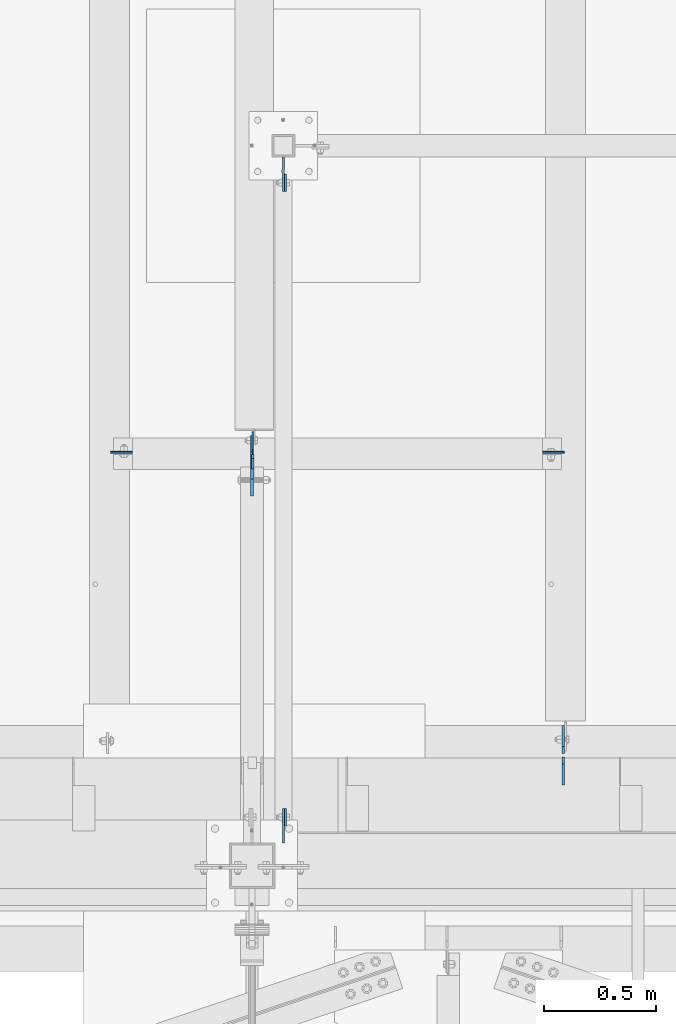
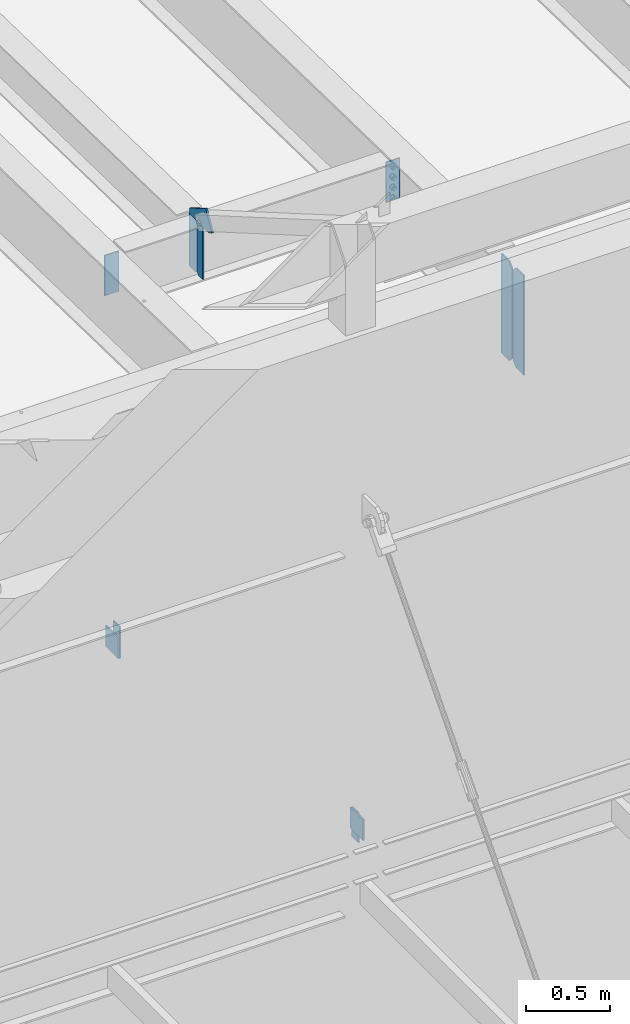
# One storey, part 1458 of 1763: 11 plates, 7 elements without a shape of their own.
"""IFC2X3 building model written with IfcOpenShell, lengths in millimetres."""

import ifcopenshell
import ifcopenshell.guid

model = None  # the IFC model being written
_history = None  # IfcOwnerHistory: only IFC2X3 demands one
_inside = {}  # id of a spatial element -> (the spatial element, [elements in it])
_under = {}  # id of a project, library or spatial element -> (it, [spatial elements below it])
_declared = {}  # id of a project -> (the project, [libraries it declares])
_typed = {}  # id of a type object -> (the type object, [elements of that type])
_made_of = {}  # id of a material, layer set ... -> (it, [elements and type objects made of it])


def new_model(schema):
    """Start an empty IFC model of exactly this schema.

    Asked for "IFC4X3", IfcOpenShell would pick the latest addendum, in which some entities
    have other attributes; the version numbers below select the first issue.
    IFC2X3 requires an IfcOwnerHistory on every rooted entity: one is made here for all.
    """
    global model, _history
    if schema == "IFC4X3":
        model = ifcopenshell.file(schema_version=(4, 3, 0, 0))
    else:
        model = ifcopenshell.file(schema=schema)
    _inside.clear()
    _under.clear()
    _declared.clear()
    _typed.clear()
    _made_of.clear()
    _history = None
    if model.schema == "IFC2X3":
        org = make("IfcOrganization", Name="unknown")
        user = make(
            "IfcPersonAndOrganization",
            ThePerson=make("IfcPerson", FamilyName="unknown"),
            TheOrganization=org,
        )
        app = make(
            "IfcApplication",
            ApplicationDeveloper=org,
            Version="unknown",
            ApplicationFullName="unknown",
            ApplicationIdentifier="unknown",
        )
        _history = make(
            "IfcOwnerHistory",
            OwningUser=user,
            OwningApplication=app,
            ChangeAction="ADDED",
            CreationDate=0,
        )
    return model


def make(cls, **values):
    """One entity of the class cls with the attributes given. An attribute that is None is left unset."""
    return model.create_entity(
        cls, **{name: value for name, value in values.items() if value is not None}
    )


def rooted(cls, **values):
    """An entity with a GlobalId (a new one), such as an element, a storey or a relation."""
    return make(cls, GlobalId=ifcopenshell.guid.new(), OwnerHistory=_history, **values)


def si_unit(unit_type, name, prefix=None):
    """IfcSIUnit, for example si_unit("LENGTHUNIT", "METRE", prefix="MILLI")."""
    return make("IfcSIUnit", UnitType=unit_type, Prefix=prefix, Name=name)


def assignment(units):
    """IfcUnitAssignment: the units of a project."""
    return None if units is None else make("IfcUnitAssignment", Units=units)


def point(xyz):
    """IfcCartesianPoint."""
    return None if xyz is None else make("IfcCartesianPoint", Coordinates=xyz)


def direction(xyz):
    """IfcDirection."""
    return None if xyz is None else make("IfcDirection", DirectionRatios=xyz)


def frame(location, z_axis=None, x_axis=None):
    """IfcAxis2Placement3D, a coordinate frame: its origin and axes. An axis left out is left unset."""
    return make(
        "IfcAxis2Placement3D",
        Location=point(location),
        Axis=direction(z_axis),
        RefDirection=direction(x_axis),
    )


def origin_with_axes():
    """The frame at (0, 0, 0) with the z axis (0, 0, 1) and the x axis (1, 0, 0) written out."""
    return frame((0.0, 0.0, 0.0), z_axis=(0.0, 0.0, 1.0), x_axis=(1.0, 0.0, 0.0))


def place(relative_to, where):
    """IfcLocalPlacement: puts the frame where relative to a parent placement (None: the world)."""
    return make(
        "IfcLocalPlacement", PlacementRelTo=relative_to, RelativePlacement=where
    )


def context(
    kind, dimensions, precision=None, world=None, true_north=None, identifier=None
):
    """IfcGeometricRepresentationContext, for example the 3D "Model" context."""
    return make(
        "IfcGeometricRepresentationContext",
        ContextIdentifier=identifier,
        ContextType=kind,
        CoordinateSpaceDimension=dimensions,
        Precision=precision,
        WorldCoordinateSystem=world,
        TrueNorth=true_north,
    )


def subcontext(parent, identifier, kind, view, scale=None):
    """IfcGeometricRepresentationSubContext, for example "Body" below "Model"."""
    return make(
        "IfcGeometricRepresentationSubContext",
        ContextIdentifier=identifier,
        ContextType=kind,
        ParentContext=parent,
        TargetScale=scale,
        TargetView=view,
    )


def project(units=None, contexts=None):
    """IfcProject with its units and contexts."""
    return rooted(
        "IfcProject",
        Name="project",
        RepresentationContexts=contexts,
        UnitsInContext=assignment(units),
    )


def spatial(cls, under=None, at=None, **own):
    """A site, building, storey or space (cls), placed at a placement, below another one or the project."""
    s = rooted(cls, ObjectPlacement=at, **own)
    if under is not None:
        _under.setdefault(under.id(), (under, []))[1].append(s)
    return s


def faces_of(points, faces, orient=None, outer=None):
    """IfcFace entities. A face is a list of loops; a loop is a list of indices into points, from 0.

    orient and outer hold one flag for each loop. By default every Orientation is true, the
    first loop of a face is its IfcFaceOuterBound and the others are IfcFaceBound.
    """
    made = []
    for i, loops in enumerate(faces):
        bounds = []
        for j, loop in enumerate(loops):
            is_outer = j == 0 if outer is None else outer[i][j]
            bounds.append(
                make(
                    "IfcFaceOuterBound" if is_outer else "IfcFaceBound",
                    Bound=make("IfcPolyLoop", Polygon=[points[k] for k in loop]),
                    Orientation=True if orient is None else orient[i][j],
                )
            )
        made.append(make("IfcFace", Bounds=bounds))
    return made


def faceted_brep(points, faces, orient=None, outer=None, voids=None):
    """IfcFacetedBrep: a solid bounded by flat faces; with voids (closed shells), ...WithVoids."""
    shared = [point(p) for p in points]
    hull = make("IfcClosedShell", CfsFaces=faces_of(shared, faces, orient, outer))
    if voids is None:
        return make("IfcFacetedBrep", Outer=hull)
    return make(
        "IfcFacetedBrepWithVoids",
        Outer=hull,
        Voids=[
            make(cls, CfsFaces=faces_of(shared, fs, o, b)) for cls, fs, o, b in voids
        ],
    )


def shape(context_of_items, identifier, shape_type, items):
    """IfcShapeRepresentation: the items that make up one representation, for example the "Body"."""
    return make(
        "IfcShapeRepresentation",
        ContextOfItems=context_of_items,
        RepresentationIdentifier=identifier,
        RepresentationType=shape_type,
        Items=items,
    )


def material(Name=None, Category=None):
    """IfcMaterial."""
    return make("IfcMaterial", Name=Name, Category=Category)


def made_of(thing, what):
    """Note that an element or type object is made of a material, layer set ...; save() writes the relation."""
    if what is not None:
        _made_of.setdefault(what.id(), (what, []))[1].append(thing)
    return thing


def type_object(cls, material=None, **own):
    """A type object (cls), such as IfcWallType, which elements share."""
    return made_of(rooted(cls, **own), material)


def element(
    cls,
    number,
    at=None,
    inside=None,
    cuts=None,
    type_object=None,
    material=None,
    context=None,
    identifier="Body",
    shape_type=None,
    held_by="IfcProductDefinitionShape",
    body=None,
    shapes=None,
    **own,
):
    """One element of the class cls, such as IfcWall. Its Tag is "e" and its number.

    at: its placement. inside: the storey or other place that contains it. cuts: it is an
    opening in that element (IfcRelVoidsElement). A single representation is given by context,
    identifier, shape_type and body (its items); several are given by shapes. held_by: the class
    of the entity that holds the representations. save() writes the other relations.
    """
    e = rooted(cls, Tag="e%d" % number, ObjectPlacement=at, **own)
    if body is not None:
        shapes = [shape(context, identifier, shape_type, body)]
    if shapes is not None:
        e.Representation = make(held_by, Representations=shapes)
    if inside is not None:
        _inside.setdefault(inside.id(), (inside, []))[1].append(e)
    if cuts is not None:
        rooted(
            "IfcRelVoidsElement", RelatingBuildingElement=cuts, RelatedOpeningElement=e
        )
    if type_object is not None:
        _typed.setdefault(type_object.id(), (type_object, []))[1].append(e)
    return made_of(e, material)


def aggregate(whole, parts):
    """IfcRelAggregates: a whole, such as a stair, and the parts it consists of."""
    return rooted("IfcRelAggregates", RelatingObject=whole, RelatedObjects=parts)


def save(model, path):
    """Write the relations noted so far, then the file.

    IfcRelAggregates (storeys below a building ...), IfcRelContainedInSpatialStructure (elements
    in a storey), IfcRelDefinesByType, IfcRelAssociatesMaterial and IfcRelDeclares: one each for
    every whole, place, type object, material and project.
    """
    for whole, parts in _under.values():
        aggregate(whole, parts)
    for where, things in _inside.values():
        rooted(
            "IfcRelContainedInSpatialStructure",
            RelatedElements=things,
            RelatingStructure=where,
        )
    for kind, things in _typed.values():
        rooted("IfcRelDefinesByType", RelatedObjects=things, RelatingType=kind)
    for what, things in _made_of.values():
        rooted("IfcRelAssociatesMaterial", RelatedObjects=things, RelatingMaterial=what)
    for by, libraries in _declared.values():
        rooted("IfcRelDeclares", RelatingContext=by, RelatedDefinitions=libraries)
    model.write(path)


model = new_model("IFC2X3")

# Units and contexts
model_context = context("Model", 3, precision=1e-05, world=origin_with_axes())
body_context = subcontext(model_context, "Body", "Model", "MODEL_VIEW")
ifc_project = project(units=[si_unit("LENGTHUNIT", "METRE", prefix="MILLI"), si_unit("AREAUNIT", "SQUARE_METRE"), si_unit("VOLUMEUNIT", "CUBIC_METRE"), si_unit("MASSUNIT", "GRAM", prefix="KILO"), si_unit("TIMEUNIT", "SECOND"), si_unit("PLANEANGLEUNIT", "RADIAN"), si_unit("SOLIDANGLEUNIT", "STERADIAN"), si_unit("THERMODYNAMICTEMPERATUREUNIT", "DEGREE_CELSIUS"), si_unit("LUMINOUSINTENSITYUNIT", "LUMEN")], contexts=[model_context])

# Site, building, storey
site_placement = place(None, origin_with_axes())
site = spatial("IfcSite", under=ifc_project, at=site_placement, CompositionType="ELEMENT")
building_placement = place(site_placement, origin_with_axes())
building = spatial("IfcBuilding", under=site, at=building_placement, Name="Undefined", CompositionType="ELEMENT")
storey_placement = place(building_placement, origin_with_axes())
storey = spatial("IfcBuildingStorey", under=building, at=storey_placement, Name="Undefined", CompositionType="ELEMENT", Elevation=0.0)

# Assembly, plates
assembly_1_placement = place(storey_placement, origin_with_axes())
assembly_1 = element("IfcElementAssembly", 1, at=assembly_1_placement, inside=storey, Name="BEAM", AssemblyPlace="NOTDEFINED", PredefinedType="RIGID_FRAME")
ifc_material = material(Name="STEEL/A36")
plate_type_1 = type_object("IfcPlateType", PredefinedType="NOTDEFINED")
plate_1_placement = place(assembly_1_placement, frame((-58778.1796871736, -14030.3570889892, 8623.30000007624), z_axis=(0.0, 0.0, 1.0), x_axis=(0.0, 1.0, 0.0)))
plate_1 = element("IfcPlate", 2, at=plate_1_placement, type_object=plate_type_1, material=ifc_material, Name="PLATE", context=body_context, shape_type="Brep", body=[
    faceted_brep([(0.0, -4.76249999999982, 0.0), (0.0294800233077694, -4.76250000068103, 215.899993896486), (0.0294800233114074, 4.76249999931315, 215.899993896483), (0.0, 4.76249999999982, 0.0), (76.2294769287091, -4.76250000057917, 215.899993896486), (76.2294769287128, 4.76249999942229, 215.899993896483), (76.1999969482931, -4.76249999991705, 0.0), (76.1999969482931, 4.76250000006257, 1.81898940354586e-12)], [[[0, 1, 2, 3]], [[1, 4, 5, 2]], [[4, 6, 7, 5]], [[6, 0, 3, 7]], [[5, 7, 3, 2]], [[6, 4, 1, 0]]]),
])
plate_2_placement = place(assembly_1_placement, frame((-58778.1796872498, -11125.1679129386, 8470.89999992377), z_axis=(0.0, 0.0, -1.0), x_axis=(0.0, -1.0, 0.0)))
plate_2 = element("IfcPlate", 3, at=plate_2_placement, type_object=plate_type_1, material=ifc_material, Name="PLATE", context=body_context, shape_type="Brep", body=[
    faceted_brep([(0.0, -4.76249999999982, 0.0), (-2.83762346953154e-10, -4.7624999996915, 228.600006103516), (-2.83762346953154e-10, 4.76250000028813, 228.600006103517), (0.0, 4.76249999999982, 0.0), (76.1999969480166, -4.76249999961874, 228.600006103516), (76.1999969480166, 4.76250000036089, 228.600006103517), (76.1999969482931, -4.76249999991705, 0.0), (76.1999969482931, 4.76250000006257, 1.81898940354586e-12)], [[[0, 1, 2, 3]], [[1, 4, 5, 2]], [[4, 6, 7, 5]], [[6, 0, 3, 7]], [[5, 7, 3, 2]], [[6, 4, 1, 0]]]),
])
aggregate(assembly_1, [plate_1, plate_2])

# Assembly, plate
assembly_2_placement = place(storey_placement, origin_with_axes())
assembly_2 = element("IfcElementAssembly", 4, at=assembly_2_placement, inside=storey, Name="BEAM", AssemblyPlace="NOTDEFINED", PredefinedType="RIGID_FRAME")
plate_type_2 = type_object("IfcPlateType", PredefinedType="NOTDEFINED")
plate_3_placement = place(assembly_2_placement, frame((-58787.7046893278, -13954.1276120796, 8839.19999998095), z_axis=(0.0, 0.0, -1.0), x_axis=(0.0, -1.0, 0.0)))
plate_3 = element("IfcPlate", 5, at=plate_3_placement, type_object=plate_type_2, material=ifc_material, Name="PLATE", context=body_context, shape_type="Brep", body=[
    faceted_brep([(0.0, -4.76249999999982, 0.0), (-3.05175672110636e-06, -4.7625000002663, 152.399993896484), (-3.05175490211695e-06, 4.76249999972788, 152.399993896484), (0.0, 4.76249999999982, 0.0), (152.400009155272, -4.76249999975698, 152.399993896484), (152.400009155273, 4.76250000024447, 152.399993896484), (152.400009155272, -4.76249999948777, 5.45696821063757e-12), (152.400009155273, 4.76250000051368, 3.63797880709171e-12)], [[[0, 1, 2, 3]], [[1, 4, 5, 2]], [[4, 6, 7, 5]], [[6, 0, 3, 7]], [[5, 7, 3, 2]], [[6, 4, 1, 0]]]),
])
aggregate(assembly_2, [plate_3])

assembly_3_placement = place(storey_placement, origin_with_axes())
assembly_3 = element("IfcElementAssembly", 6, at=assembly_3_placement, inside=storey, Name="COLUMN", AssemblyPlace="NOTDEFINED", PredefinedType="RIGID_FRAME")
plate_4_placement = place(assembly_3_placement, frame((-58787.7046893277, -11201.3679099249, 8242.29999389649), z_axis=(0.0, 0.0, 1.0), x_axis=(0.0, 1.0, 0.0)))
plate_4 = element("IfcPlate", 7, at=plate_4_placement, type_object=plate_type_2, material=ifc_material, Name="PLATE", context=body_context, shape_type="Brep", body=[
    faceted_brep([(0.0, -4.76249999999982, 0.0), (-3.05175672110636e-06, -4.7625000002663, 152.399993896484), (-3.05175490211695e-06, 4.76249999972788, 152.399993896484), (0.0, 4.76249999999982, 0.0), (152.400009155272, -4.76249999975698, 152.399993896484), (152.400009155273, 4.76250000024447, 152.399993896484), (152.400009155272, -4.76249999948777, 5.45696821063757e-12), (152.400009155273, 4.76250000051368, 3.63797880709171e-12)], [[[0, 1, 2, 3]], [[1, 4, 5, 2]], [[4, 6, 7, 5]], [[6, 0, 3, 7]], [[5, 7, 3, 2]], [[6, 4, 1, 0]]]),
])
aggregate(assembly_3, [plate_4])

# Assembly, plates
assembly_4_placement = place(storey_placement, origin_with_axes())
assembly_4 = element("IfcElementAssembly", 8, at=assembly_4_placement, inside=storey, Name="BEAM", AssemblyPlace="NOTDEFINED", PredefinedType="RIGID_FRAME")
plate_type_3 = type_object("IfcPlateType", PredefinedType="NOTDEFINED")
plate_5_placement = place(assembly_4_placement, frame((-58924.2622752818, -12368.9394876504, 11786.0798333454), z_axis=(0.0, 0.0, 1.0), x_axis=(0.0, 1.0, 0.0)))
plate_5 = element("IfcPlate", 9, at=plate_5_placement, type_object=plate_type_3, material=ifc_material, Name="PLATE", context=body_context, shape_type="Brep", body=[
    faceted_brep([(0.0, -3.17500000000291, 17.4624996185303), (0.0, -3.17500000000291, 363.53750038147), (0.0, 3.17500000000291, 363.53750038147), (0.0, 3.17500000000291, 17.4624996185303), (17.4624996185303, -3.17500000000291, 381.0), (17.4624996185303, 3.17500000000291, 381.0), (95.25, -3.17500000000291, 381.0), (95.25, 3.17500000000291, 381.0), (95.25, -3.17500000000291, 0.0), (95.25, 3.17500000000291, 0.0), (17.4624996185303, -3.17500000000291, 0.0), (17.4624996185303, 3.17500000000291, 0.0)], [[[0, 1, 2, 3]], [[1, 4, 5, 2]], [[4, 6, 7, 5]], [[6, 8, 9, 7]], [[8, 10, 11, 9]], [[10, 0, 3, 11]], [[5, 7, 9, 11, 3, 2]], [[10, 8, 6, 4, 1, 0]]]),
])
plate_type_4 = type_object("IfcPlateType", PredefinedType="NOTDEFINED")
plate_6_placement = place(assembly_4_placement, frame((-58927.4377751502, -12289.5644876527, 12176.6048333467), z_axis=(0.0, -1.0, 0.0), x_axis=(0.0, 0.0, 1.0)))
plate_6 = element("IfcPlate", 10, at=plate_6_placement, type_object=plate_type_4, material=ifc_material, Name="PLATE", context=body_context, shape_type="Brep", body=[
    faceted_brep([(0.0, -6.34999999999491, 1.45519152283669e-11), (0.0, -6.34999999999854, 165.100006103516), (0.0, 6.34999999999854, 165.100006103516), (0.0, 6.34999999999491, -2.91038304567337e-11), (0.0, -6.34999999999854, 234.421340942383), (0.0, 6.34999999999854, 234.421340942383), (20.8898239135742, -6.34999999999854, 270.436950683594), (20.8898239135742, 6.34999999999854, 270.436950683594), (152.717071533203, -6.34999999999854, 193.974349975586), (152.717071533203, 6.34999999999854, 193.974349975586), (40.2078170776367, -6.34999999999854, 0.0), (40.2078170776367, 6.34999999999854, 0.0)], [[[0, 1, 2, 3]], [[1, 4, 5, 2]], [[4, 6, 7, 5]], [[6, 8, 9, 7]], [[8, 10, 11, 9]], [[10, 0, 3, 11]], [[5, 7, 9, 11, 3, 2]], [[10, 8, 6, 4, 1, 0]]]),
])

# Assembly, plate
assembly_5_placement = place(storey_placement, origin_with_axes())
assembly_5 = element("IfcElementAssembly", 11, at=assembly_5_placement, inside=storey, Name="BEAM", AssemblyPlace="NOTDEFINED", PredefinedType="RIGID_FRAME")
plate_type_5 = type_object("IfcPlateType", PredefinedType="NOTDEFINED")
plate_7_placement = place(assembly_5_placement, frame((-57535.1997736983, -12364.9704876481, 12138.5048333448), z_axis=(-1.0, 0.0, 0.0), x_axis=(0.0, 0.0, -1.0)))
plate_7 = element("IfcPlate", 12, at=plate_7_placement, type_object=plate_type_5, material=ifc_material, Name="PLATE", context=body_context, shape_type="Brep", body=[
    faceted_brep([(0.0, -3.96900000000096, 0.0), (0.0, -3.96899999999914, 96.8375015258789), (0.0, 3.96899999999914, 96.8375015258789), (0.0, 3.96900000000096, 0.0), (292.100006103516, -3.96899999999914, 96.8375015258789), (292.100006103516, 3.96899999999914, 96.8375015258789), (292.100006103516, -3.96899999999914, 0.0), (292.100006103516, 3.96899999999914, 0.0)], [[[0, 1, 2, 3]], [[1, 4, 5, 2]], [[4, 6, 7, 5]], [[6, 0, 3, 7]], [[5, 7, 3, 2]], [[6, 4, 1, 0]]]),
])
aggregate(assembly_5, [plate_7])

assembly_6_placement = place(storey_placement, origin_with_axes())
assembly_6 = element("IfcElementAssembly", 13, at=assembly_6_placement, inside=storey, Name="BEAM", AssemblyPlace="NOTDEFINED", PredefinedType="RIGID_FRAME")
plate_8_placement = place(assembly_6_placement, frame((-59557.6747736983, -12364.9704876481, 12138.5048333448), z_axis=(1.0, 0.0, 0.0), x_axis=(0.0, 0.0, -1.0)))
plate_8 = element("IfcPlate", 14, at=plate_8_placement, type_object=plate_type_5, material=ifc_material, Name="PLATE", context=body_context, shape_type="Brep", body=[
    faceted_brep([(0.0, -3.96900000000096, 0.0), (0.0, -3.96899999999914, 96.8375015258789), (0.0, 3.96899999999914, 96.8375015258789), (0.0, 3.96900000000096, 0.0), (292.100006103516, -3.96899999999914, 96.8375015258789), (292.100006103516, 3.96899999999914, 96.8375015258789), (292.100006103516, -3.96899999999914, 0.0), (292.100006103516, 3.96899999999914, 0.0)], [[[0, 1, 2, 3]], [[1, 4, 5, 2]], [[4, 6, 7, 5]], [[6, 0, 3, 7]], [[5, 7, 3, 2]], [[6, 4, 1, 0]]]),
])
aggregate(assembly_6, [plate_8])

# Assembly, plates
assembly_7_placement = place(storey_placement, origin_with_axes())
assembly_7 = element("IfcElementAssembly", 15, at=assembly_7_placement, inside=storey, Name="BEAM", AssemblyPlace="NOTDEFINED", PredefinedType="RIGID_FRAME")
plate_type_6 = type_object("IfcPlateType", PredefinedType="NOTDEFINED")
plate_9_placement = place(assembly_7_placement, frame((-57539.9627736144, -13723.1435686171, 11464.925), z_axis=(0.0, 0.0, 1.0), x_axis=(0.0, -1.0, 0.0)))
plate_9 = element("IfcPlate", 16, at=plate_9_placement, type_object=plate_type_6, material=ifc_material, Name="PLATE", context=body_context, shape_type="Brep", body=[
    faceted_brep([(0.0, -4.76250000000073, 31.75), (0.0, -4.76249999999709, 688.974975585938), (0.0, 4.76249999999709, 688.974975585938), (0.0, 4.76250000000073, 31.75), (31.75, -4.76249999999709, 720.724975585938), (31.75, 4.76249999999709, 720.724975585938), (126.206253051758, -4.76249999999709, 720.724975585938), (126.206253051758, 4.76249999999709, 720.724975585938), (126.206253051758, -4.76249999999709, 0.0), (126.206253051758, 4.76249999999709, 0.0), (31.75, -4.76250000000073, 0.0), (31.75, 4.76250000000073, 0.0)], [[[0, 1, 2, 3]], [[1, 4, 5, 2]], [[4, 6, 7, 5]], [[6, 8, 9, 7]], [[8, 10, 11, 9]], [[10, 0, 3, 11]], [[5, 7, 9, 11, 3, 2]], [[10, 8, 6, 4, 1, 0]]]),
])
plate_type_7 = type_object("IfcPlateType", PredefinedType="NOTDEFINED")
plate_10_placement = place(assembly_7_placement, frame((-57539.9627736144, -13708.8560686171, 11466.5125), z_axis=(0.0, 0.0, 1.0), x_axis=(0.0, 1.0, 0.0)))
plate_10 = element("IfcPlate", 17, at=plate_10_placement, type_object=plate_type_7, material=ifc_material, Name="PLATE", context=body_context, shape_type="Brep", body=[
    faceted_brep([(0.0, -4.76250000000073, 31.75), (0.0, -4.76249999999709, 687.387512207031), (0.0, 4.76249999999709, 687.387512207031), (0.0, 4.76250000000073, 31.75), (31.75, -4.76249999999709, 719.137512207031), (31.75, 4.76249999999709, 719.137512207031), (125.412498474121, -4.76249999999709, 719.137512207031), (125.412498474121, 4.76249999999709, 719.137512207031), (125.412498474121, -4.76249999999709, 0.0), (125.412498474121, 4.76249999999709, 0.0), (31.75, -4.76250000000073, 0.0), (31.75, 4.76250000000073, 0.0)], [[[0, 1, 2, 3]], [[1, 4, 5, 2]], [[4, 6, 7, 5]], [[6, 8, 9, 7]], [[8, 10, 11, 9]], [[10, 0, 3, 11]], [[5, 7, 9, 11, 3, 2]], [[10, 8, 6, 4, 1, 0]]]),
])
aggregate(assembly_7, [plate_9, plate_10])

# Plate
plate_type_8 = type_object("IfcPlateType", PredefinedType="NOTDEFINED")
plate_11_placement = place(assembly_4_placement, frame((-58924.2627751502, -12375.2894876504, 11786.0798333454), z_axis=(0.0, 0.0, 1.0), x_axis=(0.0, -1.0, 0.0)))
plate_11 = element("IfcPlate", 18, at=plate_11_placement, type_object=plate_type_8, material=ifc_material, Name="PLATE", context=body_context, shape_type="Brep", body=[
    faceted_brep([(0.0, -4.76249999999709, 17.4624996185303), (0.0, -4.76249999999709, 363.53750038147), (0.0, 4.76249999999709, 363.53750038147), (0.0, 4.76249999999709, 17.4624996185303), (17.4624996185303, -4.76249999999709, 381.0), (17.4624996185303, 4.76249999999709, 381.0), (63.5, -4.76249999999709, 381.0), (63.5, 4.76249999999709, 381.0), (63.4999999999964, -4.76250000017171, 0.0), (63.5000000000036, 4.76249999982974, 0.0), (17.4624996185303, -4.76249999999709, 0.0), (17.4624996185303, 4.76249999999709, 0.0)], [[[0, 1, 2, 3]], [[1, 4, 5, 2]], [[4, 6, 7, 5]], [[6, 8, 9, 7]], [[8, 10, 11, 9]], [[10, 0, 3, 11]], [[5, 7, 9, 11, 3, 2]], [[10, 8, 6, 4, 1, 0]]]),
])

aggregate(assembly_4, [plate_6, plate_11, plate_5])

save(model, "model.ifc")
